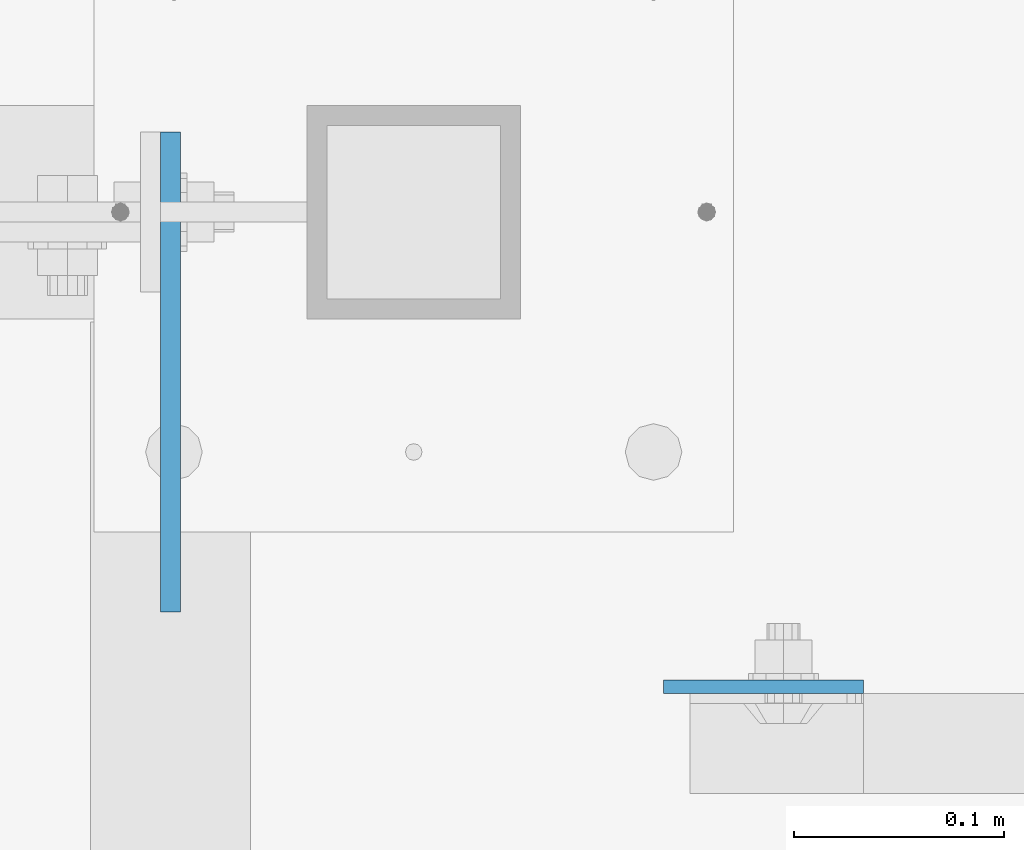
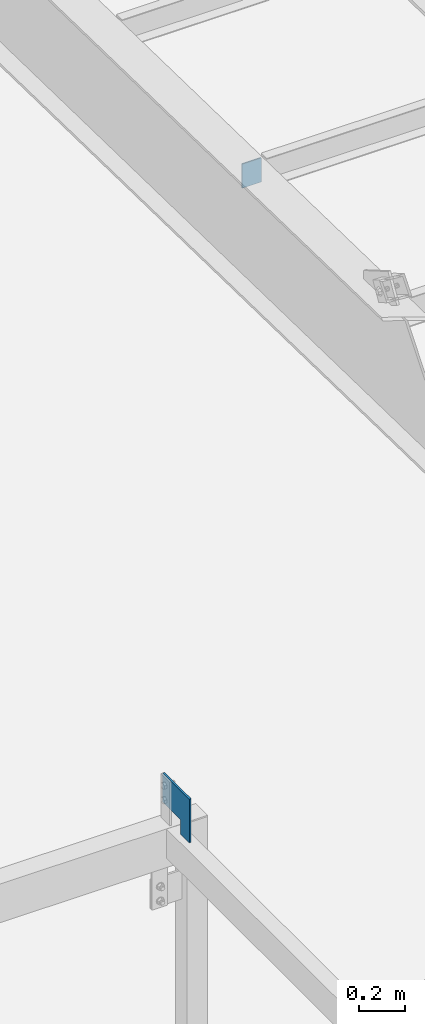
# One storey, part 1469 of 1763: 2 plates, 2 elements without a shape of their own.
"""IFC2X3 building model written with IfcOpenShell, lengths in millimetres."""

from ifc_helpers import new_model, si_unit, frame, origin_with_axes, place, context, subcontext, project, spatial, faceted_brep, material, type_object, element, aggregate, save


model = new_model("IFC2X3")

# Units and contexts
model_context = context("Model", 3, precision=1e-05, world=origin_with_axes())
body_context = subcontext(model_context, "Body", "Model", "MODEL_VIEW")
ifc_project = project(units=[si_unit("LENGTHUNIT", "METRE", prefix="MILLI"), si_unit("AREAUNIT", "SQUARE_METRE"), si_unit("VOLUMEUNIT", "CUBIC_METRE"), si_unit("MASSUNIT", "GRAM", prefix="KILO"), si_unit("TIMEUNIT", "SECOND"), si_unit("PLANEANGLEUNIT", "RADIAN"), si_unit("SOLIDANGLEUNIT", "STERADIAN"), si_unit("THERMODYNAMICTEMPERATUREUNIT", "DEGREE_CELSIUS"), si_unit("LUMINOUSINTENSITYUNIT", "LUMEN")], contexts=[model_context])

# Site, building, storey
site_placement = place(None, origin_with_axes())
site = spatial("IfcSite", under=ifc_project, at=site_placement, CompositionType="ELEMENT")
building_placement = place(site_placement, origin_with_axes())
building = spatial("IfcBuilding", under=site, at=building_placement, Name="Undefined", CompositionType="ELEMENT")
storey_placement = place(building_placement, origin_with_axes())
storey = spatial("IfcBuildingStorey", under=building, at=storey_placement, Name="Undefined", CompositionType="ELEMENT", Elevation=0.0)

# Assembly, plate
assembly_1_placement = place(storey_placement, origin_with_axes())
assembly_1 = element("IfcElementAssembly", 1, at=assembly_1_placement, inside=storey, Name="BEAM", AssemblyPlace="NOTDEFINED", PredefinedType="RIGID_FRAME")
ifc_material = material(Name="STEEL/A36")
plate_type_1 = type_object("IfcPlateType", PredefinedType="NOTDEFINED")
plate_1_placement = place(assembly_1_placement, frame((-49632.6586815906, -11188.7073335268, 8851.87788121632), z_axis=(-4.00000135414302e-09, 9.67160000327568e-05, -0.999999995323008), x_axis=(-1.2000009728941e-08, 0.999999995323008, 9.67160000319667e-05)))
plate_1 = element("IfcPlate", 2, at=plate_1_placement, type_object=plate_type_1, material=ifc_material, Name="PLATE", context=body_context, shape_type="Brep", body=[
    faceted_brep([(0.0, -4.76249999999982, 0.0), (-0.0147415312894736, -4.76250000055734, 228.577880859459), (-0.0147415312967496, 4.76249999946594, 228.577880859457), (0.0, 4.76249999999982, 0.0), (76.1926269535688, -4.76250000031723, 228.563140869262), (76.1926269535616, 4.76249999970605, 228.563140869261), (76.1999969485987, -4.76250000013533, 152.385253906345), (76.1999969485914, 4.76249999988795, 152.385253906343), (228.59263610909, -4.76249999964057, 152.399993896655), (228.592636109082, 4.76250000037544, 152.399993896655), (228.607376099128, -4.76249999928405, 2.14640749618411e-10), (228.607376099135, 4.76250000073924, 2.12821760214865e-10)], [[[0, 1, 2, 3]], [[1, 4, 5, 2]], [[4, 6, 7, 5]], [[6, 8, 9, 7]], [[8, 10, 11, 9]], [[10, 0, 3, 11]], [[5, 7, 9, 11, 3, 2]], [[10, 8, 6, 4, 1, 0]]]),
])
aggregate(assembly_1, [plate_1])

assembly_2_placement = place(storey_placement, origin_with_axes())
assembly_2 = element("IfcElementAssembly", 3, at=assembly_2_placement, inside=storey, Name="BEAM", AssemblyPlace="NOTDEFINED", PredefinedType="RIGID_FRAME")
plate_type_2 = type_object("IfcPlateType", PredefinedType="NOTDEFINED")
plate_2_placement = place(assembly_2_placement, frame((-49397.6747736984, -11224.4126198457, 12127.2773623985), z_axis=(1.0, 0.0, 0.0), x_axis=(0.0, 0.0, -1.0)))
plate_2 = element("IfcPlate", 4, at=plate_2_placement, type_object=plate_type_2, material=ifc_material, Name="PLATE", context=body_context, shape_type="Brep", body=[
    faceted_brep([(1.81898940354586e-12, -3.17500000000291, 0.0), (0.0, -3.17499999999927, 95.25), (0.0, 3.17499999999927, 95.25), (-1.81898940354586e-12, 3.17499999997381, 0.0), (127.0, -3.17499999999927, 95.25), (127.0, 3.17499999999927, 95.25), (127.0, -3.17499999999927, 0.0), (127.0, 3.17499999999927, 0.0)], [[[0, 1, 2, 3]], [[1, 4, 5, 2]], [[4, 6, 7, 5]], [[6, 0, 3, 7]], [[5, 7, 3, 2]], [[6, 4, 1, 0]]]),
])
aggregate(assembly_2, [plate_2])

save(model, "model.ifc")
